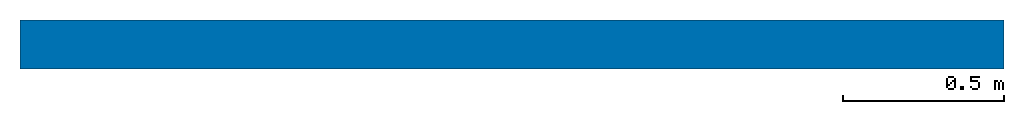
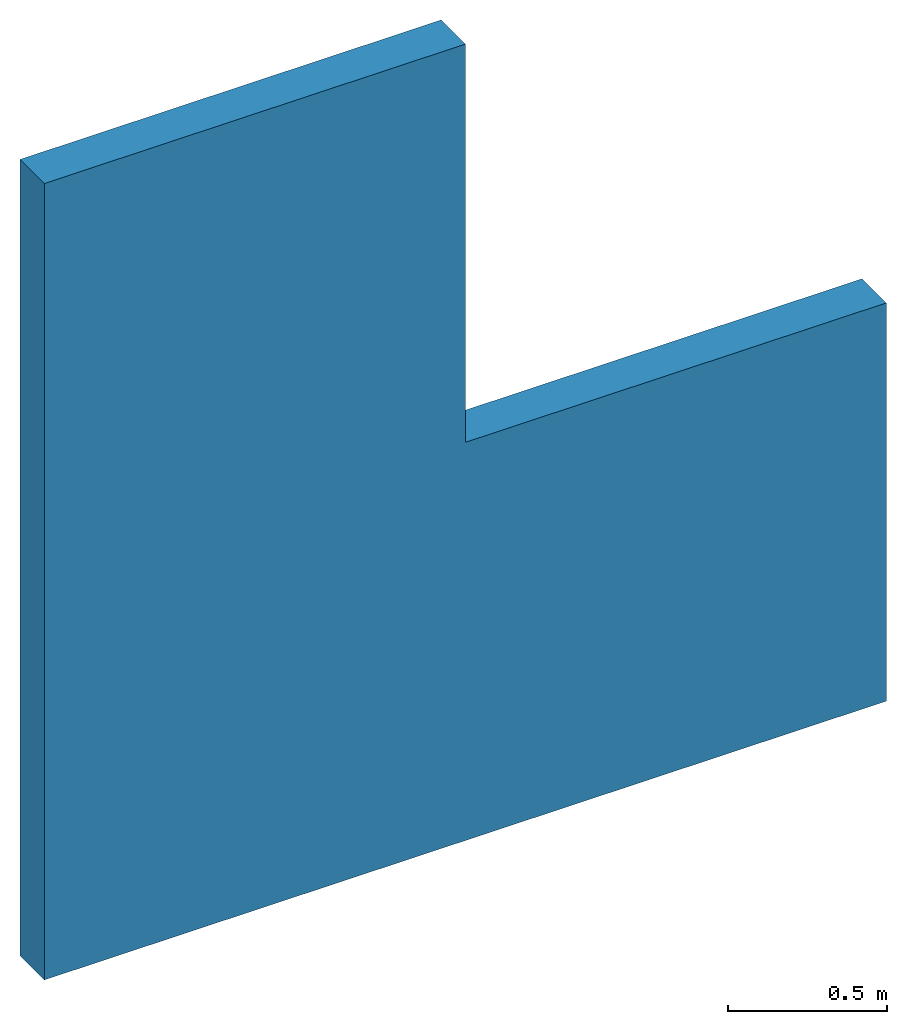
# One storey: 1 wall, 1 opening.
"""IFC4 building model written with IfcOpenShell, lengths in feet."""

from ifc_helpers import new_model, entity, si_unit, converted_unit, derived_unit, direction, frame, frame_2d, origin, origin_with_axes, place, context, subcontext, project, spatial, rectangle, extrude, material, layer, layer_set, layer_usage, type_object, element, save


model = new_model("IFC4")

# Units and contexts
model_context = context("Model", 3, precision=0.0001, world=origin(), true_north=direction((6.12303176911189e-17, 1.0)))
body_context = subcontext(model_context, "Body", "Model", "MODEL_VIEW")
ifc_project = project(units=[converted_unit("LENGTHUNIT", "FOOT", entity("IfcRatioMeasure", 0.3048), si_unit("LENGTHUNIT", "METRE"), dimensions=[1, 0, 0, 0, 0, 0, 0]), converted_unit("AREAUNIT", "SQUARE FOOT", entity("IfcRatioMeasure", 0.09290304), si_unit("AREAUNIT", "SQUARE_METRE"), dimensions=[2, 0, 0, 0, 0, 0, 0]), converted_unit("VOLUMEUNIT", "CUBIC FOOT", entity("IfcRatioMeasure", 0.028316846592), si_unit("VOLUMEUNIT", "CUBIC_METRE"), dimensions=[3, 0, 0, 0, 0, 0, 0]), converted_unit("PLANEANGLEUNIT", "DEGREE", entity("IfcRatioMeasure", 0.0174532925199433), si_unit("PLANEANGLEUNIT", "RADIAN"), dimensions=[0, 0, 0, 0, 0, 0, 0]), si_unit("MASSUNIT", "GRAM", prefix="KILO"), derived_unit("MASSDENSITYUNIT", [(si_unit("MASSUNIT", "GRAM", prefix="KILO"), 1), (si_unit("LENGTHUNIT", "METRE"), -3)]), derived_unit("MOMENTOFINERTIAUNIT", [(si_unit("LENGTHUNIT", "METRE"), 4)]), si_unit("TIMEUNIT", "SECOND"), si_unit("FREQUENCYUNIT", "HERTZ"), si_unit("THERMODYNAMICTEMPERATUREUNIT", "DEGREE_CELSIUS"), derived_unit("THERMALTRANSMITTANCEUNIT", [(si_unit("MASSUNIT", "GRAM", prefix="KILO"), 1), (si_unit("THERMODYNAMICTEMPERATUREUNIT", "KELVIN"), -1), (si_unit("TIMEUNIT", "SECOND"), -3)]), derived_unit("VOLUMETRICFLOWRATEUNIT", [(si_unit("LENGTHUNIT", "METRE"), 3), (si_unit("TIMEUNIT", "SECOND"), -1)]), si_unit("ELECTRICCURRENTUNIT", "AMPERE"), si_unit("ELECTRICVOLTAGEUNIT", "VOLT"), si_unit("POWERUNIT", "WATT"), si_unit("FORCEUNIT", "NEWTON"), si_unit("ILLUMINANCEUNIT", "LUX"), si_unit("LUMINOUSFLUXUNIT", "LUMEN"), si_unit("LUMINOUSINTENSITYUNIT", "CANDELA"), derived_unit("USERDEFINED", [(si_unit("MASSUNIT", "GRAM", prefix="KILO"), -1), (si_unit("LENGTHUNIT", "METRE"), -2), (si_unit("TIMEUNIT", "SECOND"), 3), (si_unit("LUMINOUSFLUXUNIT", "LUMEN"), 1)]), derived_unit("LINEARVELOCITYUNIT", [(si_unit("LENGTHUNIT", "METRE"), 1), (si_unit("TIMEUNIT", "SECOND"), -1)]), si_unit("PRESSUREUNIT", "PASCAL"), derived_unit("USERDEFINED", [(si_unit("LENGTHUNIT", "METRE"), -2), (si_unit("MASSUNIT", "GRAM", prefix="KILO"), 1), (si_unit("TIMEUNIT", "SECOND"), -2)]), derived_unit("LINEARFORCEUNIT", [(si_unit("MASSUNIT", "GRAM", prefix="KILO"), 1), (si_unit("LENGTHUNIT", "METRE"), 1), (si_unit("TIMEUNIT", "SECOND"), -2), (si_unit("LENGTHUNIT", "METRE"), -1)]), derived_unit("PLANARFORCEUNIT", [(si_unit("MASSUNIT", "GRAM", prefix="KILO"), 1), (si_unit("LENGTHUNIT", "METRE"), 1), (si_unit("TIMEUNIT", "SECOND"), -2), (si_unit("LENGTHUNIT", "METRE"), -2)])], contexts=[model_context])

# Site, building, storey
site_placement = place(None, origin())
site = spatial("IfcSite", under=ifc_project, at=site_placement, CompositionType="ELEMENT")
building_placement = place(site_placement, origin())
building = spatial("IfcBuilding", under=site, at=building_placement, CompositionType="ELEMENT")
storey_placement = place(building_placement, origin())
storey = spatial("IfcBuildingStorey", under=building, at=storey_placement, Name="Level 1", CompositionType="ELEMENT", Elevation=0.0)

# Wall, opening
ifc_material = material(Name="Wall Material", Category="Materials")
ifc_layer = layer(ifc_material, 0.5, Name="Wall Material", Category="Materials")
ifc_layer_set = layer_set([ifc_layer], Name="Basic Wall:Wall Type")
ifc_layer_usage = layer_usage(ifc_layer_set, "AXIS2", "NEGATIVE", 0.25)
wall_type = type_object("IfcWallType", Name="Basic Wall:Wall Type", PredefinedType="NOTDEFINED", material=ifc_layer_set)
wall_placement = place(storey_placement, origin_with_axes())
wall = element("IfcWall", 1, at=wall_placement, inside=storey, type_object=wall_type, material=ifc_layer_usage, Name="Basic Wall:Wall Type", ObjectType="Basic Wall:Wall Type", PredefinedType="NOTDEFINED", context=body_context, shape_type="SweptSolid", body=[
    extrude(rectangle(XDim=10.0000000990064, YDim=0.500000000940452), frame((5.00000015957149, 0.0, 0.0), z_axis=(0.0, 0.0, -1.0), x_axis=(-1.0, 0.0, 0.0)), (0.0, 0.0, -1.0), 10.0000000990064),
])
opening_placement = place(wall_placement, origin_with_axes())
element("IfcOpeningElement", 2, at=opening_placement, cuts=wall, Name="Basic Wall:Wall Type", ObjectType="Opening", PredefinedType="OPENING", context=body_context, shape_type="SweptSolid", body=[
    extrude(rectangle(XDim=5.0, YDim=4.99999999999998, at=frame_2d((3.5527136788005e-15, 3.99680288865056e-15), x_axis=(1.0, 0.0))), frame((7.5, 0.25, 7.5), z_axis=(0.0, -1.0, 0.0), x_axis=(0.0, 0.0, 1.0)), (0.0, 0.0, 1.0), 0.5),
])

save(model, "model.ifc")
